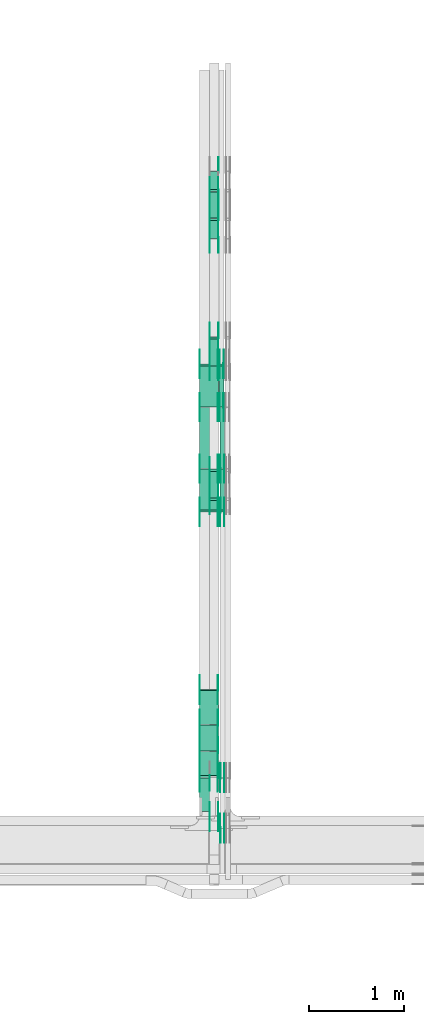
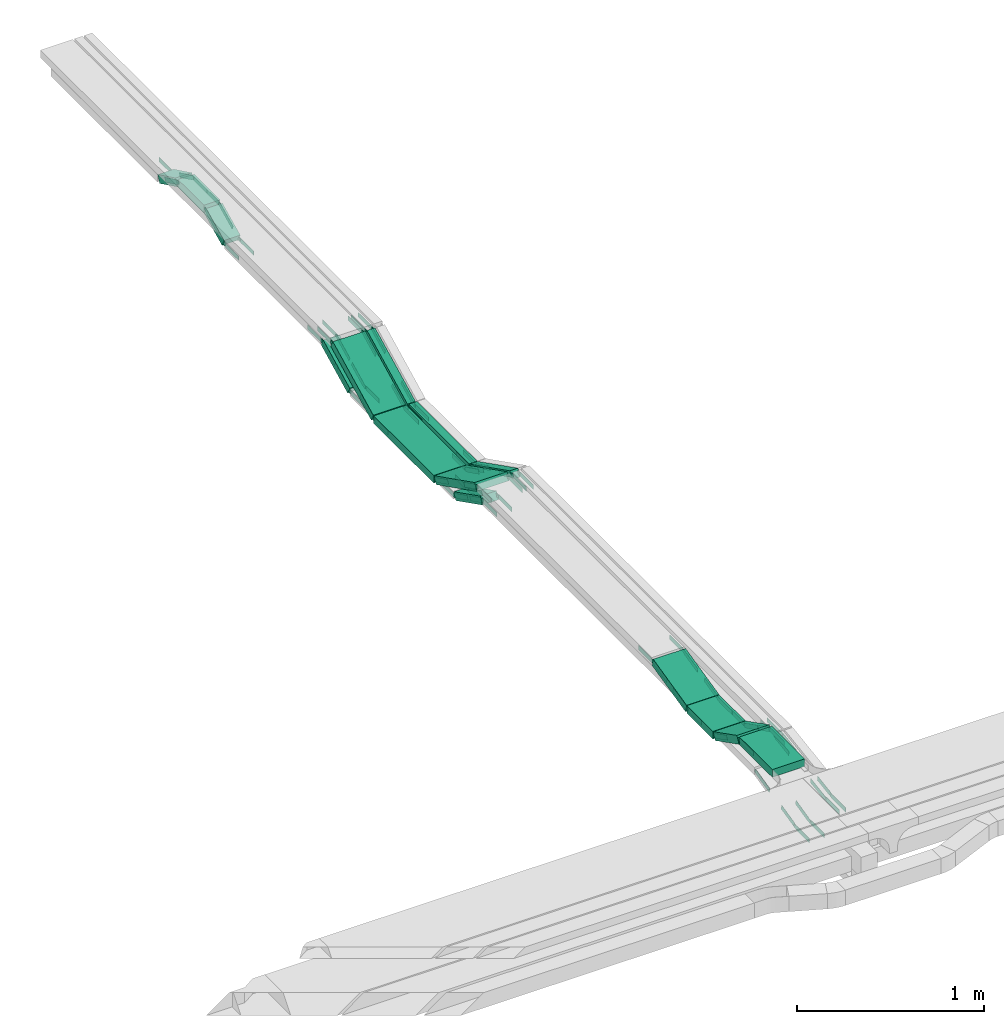
# One storey, part 18 of 28: 90 flow fittings, 15 flow segments.
"""IFC2X3 building model written with IfcOpenShell, lengths in millimetres."""

from ifc_helpers import new_model, entity, si_unit, converted_unit, derived_unit, direction, frame, frame_2d, origin, origin_2d_with_axis, place, context, subcontext, project, spatial, polyline, circle_curve, parameter, trimmed, segment, composite_curve, rectangle, outline, extrude, source, transform, mapped, material, type_object, type_shapes, element, save


model = new_model("IFC2X3")

# Units and contexts
model_context = context("Model", 3, precision=0.01, world=origin(), true_north=direction((6.12303176911189e-17, 1.0)))
body_context = subcontext(model_context, "Body", "Model", "MODEL_VIEW")
ifc_project = project(units=[si_unit("LENGTHUNIT", "METRE", prefix="MILLI"), si_unit("AREAUNIT", "SQUARE_METRE"), si_unit("VOLUMEUNIT", "CUBIC_METRE"), converted_unit("PLANEANGLEUNIT", "DEGREE", entity("IfcRatioMeasure", 0.0174532925199433), si_unit("PLANEANGLEUNIT", "RADIAN"), dimensions=[0, 0, 0, 0, 0, 0, 0]), si_unit("MASSUNIT", "GRAM", prefix="KILO"), derived_unit("MASSDENSITYUNIT", [(si_unit("MASSUNIT", "GRAM", prefix="KILO"), 1), (si_unit("LENGTHUNIT", "METRE"), -3)]), derived_unit("MOMENTOFINERTIAUNIT", [(si_unit("LENGTHUNIT", "METRE"), 4)]), si_unit("TIMEUNIT", "SECOND"), si_unit("FREQUENCYUNIT", "HERTZ"), si_unit("THERMODYNAMICTEMPERATUREUNIT", "DEGREE_CELSIUS"), derived_unit("THERMALTRANSMITTANCEUNIT", [(si_unit("MASSUNIT", "GRAM", prefix="KILO"), 1), (si_unit("THERMODYNAMICTEMPERATUREUNIT", "KELVIN"), -1), (si_unit("TIMEUNIT", "SECOND"), -3)]), derived_unit("VOLUMETRICFLOWRATEUNIT", [(si_unit("LENGTHUNIT", "METRE"), 3), (si_unit("TIMEUNIT", "SECOND"), -1)]), derived_unit("MASSFLOWRATEUNIT", [(si_unit("MASSUNIT", "GRAM", prefix="KILO"), 1), (si_unit("TIMEUNIT", "SECOND"), -1)]), derived_unit("ROTATIONALFREQUENCYUNIT", [(si_unit("TIMEUNIT", "SECOND"), -1)]), si_unit("ELECTRICCURRENTUNIT", "AMPERE"), si_unit("ELECTRICVOLTAGEUNIT", "VOLT"), si_unit("POWERUNIT", "WATT"), si_unit("FORCEUNIT", "NEWTON", prefix="KILO"), si_unit("ILLUMINANCEUNIT", "LUX"), si_unit("LUMINOUSFLUXUNIT", "LUMEN"), si_unit("LUMINOUSINTENSITYUNIT", "CANDELA"), derived_unit("USERDEFINED", [(si_unit("MASSUNIT", "GRAM", prefix="KILO"), -1), (si_unit("LENGTHUNIT", "METRE"), -2), (si_unit("TIMEUNIT", "SECOND"), 3), (si_unit("LUMINOUSFLUXUNIT", "LUMEN"), 1)]), derived_unit("LINEARVELOCITYUNIT", [(si_unit("LENGTHUNIT", "METRE"), 1), (si_unit("TIMEUNIT", "SECOND"), -1)]), si_unit("PRESSUREUNIT", "PASCAL"), derived_unit("USERDEFINED", [(si_unit("LENGTHUNIT", "METRE"), -2), (si_unit("MASSUNIT", "GRAM", prefix="KILO"), 1), (si_unit("TIMEUNIT", "SECOND"), -2)]), derived_unit("LINEARFORCEUNIT", [(si_unit("MASSUNIT", "GRAM", prefix="KILO"), 1), (si_unit("LENGTHUNIT", "METRE"), 1), (si_unit("TIMEUNIT", "SECOND"), -2), (si_unit("LENGTHUNIT", "METRE"), -1)]), derived_unit("PLANARFORCEUNIT", [(si_unit("MASSUNIT", "GRAM", prefix="KILO"), 1), (si_unit("LENGTHUNIT", "METRE"), 1), (si_unit("TIMEUNIT", "SECOND"), -2), (si_unit("LENGTHUNIT", "METRE"), -2)])], contexts=[model_context])

# Site, building, storey
site_placement = place(None, frame((0.0, -0.00077364408347762, 0.0)))
site = spatial("IfcSite", under=ifc_project, at=site_placement, CompositionType="ELEMENT")
building_placement = place(site_placement, origin())
building = spatial("IfcBuilding", under=site, at=building_placement, CompositionType="ELEMENT")
storey_placement = place(building_placement, origin())
storey = spatial("IfcBuildingStorey", under=building, at=storey_placement, CompositionType="ELEMENT", Elevation=0.0)

# Flow segments
cable_carrier_segment_type = type_object("IfcCableCarrierSegmentType", PredefinedType="CABLETRAYSEGMENT")
flow_segment_1_placement = place(storey_placement, frame((46847.7697248975, 13767.2948967149, 2456.22912852287)))
element("IfcFlowSegment", 1, at=flow_segment_1_placement, inside=storey, type_object=cable_carrier_segment_type, context=body_context, shape_type="SweptSolid", body=[
    extrude(rectangle(XDim=50.0000000000002, YDim=317.472558766538, at=frame_2d((0.0, 0.0), x_axis=(0.0, 1.0))), frame((0.0, 153.000824609062, 93.7708714771263), z_axis=(1.0, 0.0, 0.0), x_axis=(0.0, -0.892980854207483, -0.450094650066931)), (0.0, 0.0, 1.0), 99.9999999999946),
])
flow_segment_2_placement = place(storey_placement, frame((46847.7697248975, 12350.3050523624, 2456.22912852286)))
element("IfcFlowSegment", 2, at=flow_segment_2_placement, inside=storey, type_object=cable_carrier_segment_type, context=body_context, shape_type="SweptSolid", body=[
    extrude(rectangle(XDim=50.0000000000016, YDim=317.472558766714, at=frame_2d((2.41584530158434e-13, -4.81392703477468e-13), x_axis=(0.0, 1.0))), frame((0.0, 153.000824609155, 93.7708714771301), z_axis=(1.0, 0.0, 0.0), x_axis=(0.0, 0.89298085420761, -0.45009465006668)), (0.0, 0.0, 1.0), 99.9999999999946),
])
flow_segment_3_placement = place(storey_placement, frame((46959.820904201, 12227.7977453007, 2581.18180349081)))
element("IfcFlowSegment", 3, at=flow_segment_3_placement, inside=storey, type_object=cable_carrier_segment_type, context=body_context, shape_type="SweptSolid", body=[
    extrude(rectangle(XDim=49.9999999999997, YDim=484.209321850172, at=frame_2d((0.0, 0.0), x_axis=(0.0, 1.0))), frame((0.0, 227.447193172448, 131.294533993179), z_axis=(1.0, 0.0, 0.0), x_axis=(0.0, 0.892980854208928, -0.450094650064066)), (0.0, 0.0, 1.0), 50.000000000006),
])
flow_segment_4_placement = place(storey_placement, frame((46959.820904201, 12686.3854911002, 2574.95267496797)))
element("IfcFlowSegment", 4, at=flow_segment_4_placement, inside=storey, type_object=cable_carrier_segment_type, context=body_context, shape_type="SweptSolid", body=[
    extrude(rectangle(XDim=642.104660924055, YDim=50.000000000006, at=origin_2d_with_axis()), frame((25.0, 321.052330462028, 0.0), z_axis=(0.0, 0.0, 1.0), x_axis=(0.0, 1.0, 0.0)), (0.0, 0.0, 1.0), 49.9999999999995),
])
flow_segment_5_placement = place(storey_placement, frame((46952.1849606245, 13332.1835114787, 2581.18180348874)))
element("IfcFlowSegment", 5, at=flow_segment_5_placement, inside=storey, type_object=cable_carrier_segment_type, context=body_context, shape_type="SweptSolid", body=[
    extrude(rectangle(XDim=50.000000000001, YDim=484.209321850269, at=frame_2d((1.20792265079217e-12, 0.0), x_axis=(0.0, 1.0))), frame((0.0, 227.44719317206, 131.29453399422), z_axis=(1.0, 0.0, 0.0), x_axis=(0.0, -0.892980854206691, -0.450094650068503)), (0.0, 0.0, 1.0), 50.000000000006),
])
flow_segment_6_placement = place(storey_placement, frame((46742.1849606245, 12227.7977453008, 2581.18180349039)))
element("IfcFlowSegment", 6, at=flow_segment_6_placement, inside=storey, type_object=cable_carrier_segment_type, context=body_context, shape_type="SweptSolid", body=[
    extrude(rectangle(XDim=50.0000000000007, YDim=484.209321849835, at=frame_2d((1.27897692436818e-13, -2.36255459640233e-13), x_axis=(0.0, 1.0))), frame((0.0, 227.447193172292, 131.294533993118), z_axis=(1.0, 0.0, 0.0), x_axis=(0.0, 0.892980854208896, -0.450094650064129)), (0.0, 0.0, 1.0), 200.000000000007),
])
flow_segment_7_placement = place(storey_placement, frame((46742.1849606245, 12686.3854911, 2574.95267496752)))
element("IfcFlowSegment", 7, at=flow_segment_7_placement, inside=storey, type_object=cable_carrier_segment_type, context=body_context, shape_type="SweptSolid", body=[
    extrude(rectangle(XDim=642.104660927451, YDim=200.000000000007, at=frame_2d((-2.1600499167107e-12, 0.0), x_axis=(1.0, 0.0))), frame((100.0, 321.052330463728, 0.0), z_axis=(0.0, 0.0, 1.0), x_axis=(0.0, 1.0, 0.0)), (0.0, 0.0, 1.0), 50.0000000000005),
])
flow_segment_8_placement = place(storey_placement, frame((46742.1849606245, 13332.183511482, 2581.18180349044)))
element("IfcFlowSegment", 8, at=flow_segment_8_placement, inside=storey, type_object=cable_carrier_segment_type, context=body_context, shape_type="SweptSolid", body=[
    extrude(rectangle(XDim=50.0000000000005, YDim=484.209321846522, at=frame_2d((0.0, 0.0), x_axis=(0.0, 1.0))), frame((0.0, 227.447193170405, 131.294533993333), z_axis=(1.0, 0.0, 0.0), x_axis=(0.0, -0.892980854206786, -0.450094650068315)), (0.0, 0.0, 1.0), 200.000000000007),
])
flow_segment_9_placement = place(storey_placement, frame((46742.1849606245, 9070.00006103515, 2850.0)))
element("IfcFlowSegment", 9, at=flow_segment_9_placement, inside=storey, type_object=cable_carrier_segment_type, context=body_context, shape_type="SweptSolid", body=[
    extrude(rectangle(XDim=352.037715986697, YDim=200.000000000007, at=origin_2d_with_axis()), frame((100.0, 176.018857993349, 0.0), z_axis=(0.0, 0.0, 1.0), x_axis=(0.0, 1.0, 0.0)), (0.0, 0.0, 1.0), 49.9999999999995),
])
flow_segment_10_placement = place(storey_placement, frame((46742.1849606245, 9425.74474554499, 2720.14248827121)))
element("IfcFlowSegment", 10, at=flow_segment_10_placement, inside=storey, type_object=cable_carrier_segment_type, context=body_context, shape_type="SweptSolid", body=[
    extrude(rectangle(XDim=49.9999999999994, YDim=284.075431974124, at=frame_2d((3.5527136788005e-13, 4.86721773995669e-13), x_axis=(0.0, 1.0))), frame((0.0, 137.906294118772, 86.7589367675452), z_axis=(1.0, 0.0, 0.0), x_axis=(0.0, 0.891006524188341, -0.453990499739599)), (0.0, 0.0, 1.0), 200.000000000007),
])
flow_segment_11_placement = place(storey_placement, frame((46742.1849606245, 9705.26430230569, 2713.80285007765)))
element("IfcFlowSegment", 11, at=flow_segment_11_placement, inside=storey, type_object=cable_carrier_segment_type, context=body_context, shape_type="SweptSolid", body=[
    extrude(rectangle(XDim=277.662391313806, YDim=200.000000000007, at=frame_2d((5.54223333892878e-13, 0.0), x_axis=(1.0, 0.0))), frame((100.0, 138.831195656904, 0.0), z_axis=(0.0, 0.0, 1.0), x_axis=(0.0, 1.0, 0.0)), (0.0, 0.0, 1.0), 49.9999999999995),
])
flow_segment_12_placement = place(storey_placement, frame((46742.1849606245, 9985.81864117691, 2715.4760141411)))
element("IfcFlowSegment", 12, at=flow_segment_12_placement, inside=storey, type_object=cable_carrier_segment_type, context=body_context, shape_type="SweptSolid", body=[
    extrude(rectangle(XDim=49.9999999999991, YDim=366.558489644676, at=frame_2d((-1.06581410364015e-12, 2.45137243837235e-13), x_axis=(0.0, 1.0))), frame((0.0, 184.121681664649, 66.4254108974635), z_axis=(1.0, 0.0, 0.0), x_axis=(0.0, 0.973268623518919, 0.229669733473065)), (0.0, 0.0, 1.0), 200.000000000007),
])
flow_segment_13_placement = place(storey_placement, frame((46847.7697248975, 15325.7073557057, 2700.0)))
element("IfcFlowSegment", 13, at=flow_segment_13_placement, inside=storey, type_object=cable_carrier_segment_type, context=body_context, shape_type="SweptSolid", body=[
    extrude(rectangle(XDim=276.67146144988, YDim=99.9999999999946, at=origin_2d_with_axis()), frame((50.0, 138.33573072494, 0.0), z_axis=(0.0, 0.0, 1.0), x_axis=(0.0, 1.0, 0.0)), (0.0, 0.0, 1.0), 49.9999999999995),
])
flow_segment_14_placement = place(storey_placement, frame((46847.7697248975, 15108.938895096, 2605.90349264662)))
element("IfcFlowSegment", 14, at=flow_segment_14_placement, inside=storey, type_object=cable_carrier_segment_type, context=body_context, shape_type="SweptSolid", body=[
    extrude(rectangle(XDim=50.0000000000002, YDim=212.726848185128, at=frame_2d((1.13686837721616e-13, 2.45137243837235e-13), x_axis=(0.0, 1.0))), frame((0.0, 106.558090988111, 69.0965073533718), z_axis=(1.0, 0.0, 0.0), x_axis=(0.0, -0.89879404629905, -0.438371146789316)), (0.0, 0.0, 1.0), 99.9999999999946),
])
flow_segment_15_placement = place(storey_placement, frame((46847.7697248975, 15606.031095789, 2605.90349264662)))
element("IfcFlowSegment", 15, at=flow_segment_15_placement, inside=storey, type_object=cable_carrier_segment_type, context=body_context, shape_type="SweptSolid", body=[
    extrude(rectangle(XDim=50.0000000000002, YDim=212.726848185074, at=frame_2d((1.08713038571295e-12, 2.34479102800833e-13), x_axis=(0.0, 1.0))), frame((0.0, 106.558090988081, 69.0965073533702), z_axis=(1.0, 0.0, 0.0), x_axis=(0.0, 0.898794046298997, -0.438371146789427)), (0.0, 0.0, 1.0), 99.9999999999945),
])

# Flow fittings
ifc_material = material(Name="G")
cable_carrier_fitting_type_1 = type_object("IfcCableCarrierFittingType", PredefinedType="NOTDEFINED", material=ifc_material)
shared_shape_1 = source(origin(), body_context, "Body", "SweptSolid", [
    extrude(outline(composite_curve([segment(trimmed(circle_curve(frame_2d((-44.5901162790698, 0.0), x_axis=(1.0, 0.0)), 12.5), [parameter(90.0000000000007)], [parameter(270.0)], True, "PARAMETER"), True, "CONTINUOUS"), segment(polyline([(-44.5901162790697, -12.5), (-33.0901162790698, -12.5)]), True, "CONTINUOUS"), segment(polyline([(-33.0901162790698, -12.5), (-31.2296511627907, -14.5)]), True, "CONTINUOUS"), segment(polyline([(-31.2296511627907, -14.5), (108.90988372093, -14.5)]), True, "CONTINUOUS"), segment(polyline([(108.90988372093, -14.5), (108.90988372093, 14.5)]), True, "CONTINUOUS"), segment(polyline([(108.90988372093, 14.5), (-31.2296511627907, 14.5)]), True, "CONTINUOUS"), segment(polyline([(-31.2296511627907, 14.5), (-33.0901162790698, 12.5)]), True, "CONTINUOUS"), segment(polyline([(-33.0901162790698, 12.5), (-44.5901162790699, 12.5)]), True, "CONTINUOUS")], self_intersect=False)), frame((44.5901162790698, 0.0, 0.0), z_axis=(0.0, 0.0, -1.0), x_axis=(1.0, 0.0, 0.0)), (0.0, 0.0, -1.0), 2.0),
])
type_shapes(cable_carrier_fitting_type_1, [shared_shape_1])
for number, where, z_axis, x_axis in (
    (16, (46852.3097248873, 13771.4968763353, 2475.0), (-1.0, 0.0, 0.0), (0.0, -1.0, 0.0)),
    (17, (46943.2297249076, 12652.1047219603, 2475.0), (1.0, 0.0, 0.0), (0.0, 1.0, 0.0)),
    (18, (46943.2297249076, 12354.5070319827, 2625.0), (1.0, 0.0, 0.0), (0.0, -1.0, 0.0)),
    (19, (47005.2809042112, 12678.4901520253, 2599.95267496795), (1.0, 0.0, 0.0), (0.0, 1.0, 0.0)),
    (20, (46956.7249606144, 13782.8759182024, 2825.0), (-1.0, 0.0, 0.0), (0.0, 1.0, 0.0)),
    (21, (47005.2809042112, 12231.999724921, 2825.0), (1.0, 0.0, 0.0), (0.0, -1.0, 0.0)),
    (22, (46852.3097248873, 9016.12655809133, 2525.0), (-1.0, 0.0, 0.0), (0.0, -1.0, 0.0)),
    (23, (47005.2809042112, 8892.27683044921, 2745.0), (1.0, 0.0, 0.0), (0.0, 0.988943608506527, 0.148292073942234)),
    (24, (47005.2809042112, 9425.78807334492, 2825.0), (1.0, 0.0, 0.0), (0.0, -0.988943608506527, -0.148292073942234)),
    (25, (46746.7249606143, 9430.00006103517, 2875.0), (-1.0, 0.0, 0.0), (0.0, 0.891006524188341, -0.4539904997396)),
    (26, (46937.6449606347, 9697.30201829235, 2738.80285007763), (1.0, 0.0, 0.0), (0.0, 1.0, 0.0)),
    (27, (46937.6449606347, 9987.30201829213, 2738.80285007763), (1.0, 0.0, 0.0), (0.0, 0.97326862351892, 0.229669733473063)),
    (28, (46937.6449606347, 12231.9997249211, 2825.0), (1.0, 0.0, 0.0), (0.0, -1.0, 0.0)),
    (29, (46746.7249606143, 10352.578627391, 2825.0), (-1.0, 0.0, 0.0), (0.0, 1.0, 0.0)),
    (30, (46852.3097248873, 15318.012178163, 2725.0), (-1.0, 0.0, 0.0), (0.0, 1.0, 0.0)),
    (31, (46943.2297249076, 15610.0739946982, 2725.0), (1.0, 0.0, 0.0), (0.0, -1.0, 0.0)),
    (32, (46943.2297249076, 15815.1043788559, 2625.0), (1.0, 0.0, 0.0), (0.0, 1.0, 0.0)),
    (33, (46852.3097248873, 14069.0945663126, 2625.0), (-1.0, 0.0, 0.0), (0.0, 1.0, 0.0)),
    (34, (46852.3097248873, 15112.9817940052, 2625.0), (-1.0, 0.0, 0.0), (0.0, -1.0, 0.0)),
    (35, (46937.6449606347, 12678.4901520252, 2599.95267496753), (1.0, 0.0, 0.0), (0.0, 1.0, 0.0)),
    (36, (46937.6449606347, 13782.8759182024, 2825.0), (1.0, 0.0, 0.0), (0.0, -0.892980854206745, -0.450094650068397)),
    (37, (46937.6449606347, 13336.3854911024, 2599.95267496751), (1.0, 0.0, 0.0), (0.0, 0.892980854206745, 0.450094650068397)),
):
    element("IfcFlowFitting", number, at=place(storey_placement, frame(where, z_axis=z_axis, x_axis=x_axis)), inside=storey, type_object=cable_carrier_fitting_type_1, material=ifc_material, context=body_context, shape_type="MappedRepresentation", body=[
        mapped(shared_shape_1, transform((0.0, 0.0, 0.0), scale=1.0)),
    ])
cable_carrier_fitting_type_2 = type_object("IfcCableCarrierFittingType", PredefinedType="NOTDEFINED", material=ifc_material)
shared_shape_2 = source(origin(), body_context, "Body", "SweptSolid", [
    extrude(outline(composite_curve([segment(trimmed(circle_curve(frame_2d((-44.5901162790697, 0.0), x_axis=(1.0, 0.0)), 12.5), [parameter(90.0000000000007)], [parameter(270.0)], True, "PARAMETER"), True, "CONTINUOUS"), segment(polyline([(-44.5901162790697, -12.5), (-33.0901162790697, -12.5)]), True, "CONTINUOUS"), segment(polyline([(-33.0901162790697, -12.5), (-31.2296511627907, -14.5)]), True, "CONTINUOUS"), segment(polyline([(-31.2296511627907, -14.5), (108.90988372093, -14.5)]), True, "CONTINUOUS"), segment(polyline([(108.90988372093, -14.5), (108.90988372093, 14.5)]), True, "CONTINUOUS"), segment(polyline([(108.90988372093, 14.5), (-31.2296511627907, 14.5)]), True, "CONTINUOUS"), segment(polyline([(-31.2296511627907, 14.5), (-33.0901162790698, 12.5)]), True, "CONTINUOUS"), segment(polyline([(-33.0901162790698, 12.5), (-44.5901162790699, 12.5)]), True, "CONTINUOUS")], self_intersect=False)), frame((44.5901162790697, 0.0, 0.0)), (0.0, 0.0, 1.0), 2.0),
])
type_shapes(cable_carrier_fitting_type_2, [shared_shape_2])
for number, where, z_axis, x_axis in (
    (38, (46943.2297249076, 13771.4968763353, 2475.0), (1.0, 0.0, 0.0), (0.0, -1.0, 0.0)),
    (39, (46852.3097248873, 12652.1047219603, 2475.0), (-1.0, 0.0, 0.0), (0.0, 1.0, 0.0)),
    (40, (46852.3097248873, 12354.5070319827, 2625.0), (-1.0, 0.0, 0.0), (0.0, -1.0, 0.0)),
    (41, (46964.3609041909, 12678.4901520253, 2599.95267496795), (-1.0, 0.0, 0.0), (0.0, 1.0, 0.0)),
    (42, (46997.6449606347, 13782.8759182024, 2825.0), (1.0, 0.0, 0.0), (0.0, 1.0, 0.0)),
    (43, (46964.3609041909, 12231.999724921, 2825.0), (-1.0, 0.0, 0.0), (0.0, -1.0, 0.0)),
    (44, (46943.2297249076, 9016.12655809133, 2525.0), (1.0, 0.0, 0.0), (0.0, -1.0, 0.0)),
    (45, (46964.3609041909, 8892.27683044921, 2745.0), (-1.0, 0.0, 0.0), (0.0, 0.988943608506527, 0.148292073942234)),
    (46, (46964.3609041909, 9425.78807334492, 2825.0), (-1.0, 0.0, 0.0), (0.0, -0.988943608506527, -0.148292073942234)),
    (47, (46937.6449606347, 9430.00006103517, 2875.0), (1.0, 0.0, 0.0), (0.0, 0.891006524188341, -0.4539904997396)),
    (48, (46746.7249606143, 9697.30201829235, 2738.80285007763), (-1.0, 0.0, 0.0), (0.0, 1.0, 0.0)),
    (49, (46746.7249606143, 9987.30201829213, 2738.80285007763), (-1.0, 0.0, 0.0), (0.0, 0.97326862351892, 0.229669733473063)),
    (50, (46746.7249606143, 12231.9997249211, 2825.0), (-1.0, 0.0, 0.0), (0.0, -1.0, 0.0)),
    (51, (46937.6449606347, 10352.578627391, 2825.0), (1.0, 0.0, 0.0), (0.0, 1.0, 0.0)),
    (52, (46943.2297249076, 15318.012178163, 2725.0), (1.0, 0.0, 0.0), (0.0, 1.0, 0.0)),
    (53, (46852.3097248873, 15610.0739946982, 2725.0), (-1.0, 0.0, 0.0), (0.0, -1.0, 0.0)),
    (54, (46943.2297249076, 14069.0945663126, 2625.0), (1.0, 0.0, 0.0), (0.0, 1.0, 0.0)),
    (55, (46943.2297249076, 15112.9817940052, 2625.0), (1.0, 0.0, 0.0), (0.0, -1.0, 0.0)),
    (56, (46746.7249606143, 12678.4901520252, 2599.95267496752), (-1.0, 0.0, 0.0), (0.0, 1.0, 0.0)),
    (57, (46746.7249606143, 13782.8759182024, 2825.0), (-1.0, 0.0, 0.0), (0.0, -0.892980854206745, -0.450094650068397)),
    (58, (46746.7249606143, 13336.3854911023, 2599.95267496751), (-1.0, 0.0, 0.0), (0.0, 0.892980854206745, 0.450094650068397)),
):
    element("IfcFlowFitting", number, at=place(storey_placement, frame(where, z_axis=z_axis, x_axis=x_axis)), inside=storey, type_object=cable_carrier_fitting_type_2, material=ifc_material, context=body_context, shape_type="MappedRepresentation", body=[
        mapped(shared_shape_2, transform((0.0, 0.0, 0.0), scale=1.0)),
    ])
cable_carrier_fitting_type_3 = type_object("IfcCableCarrierFittingType", PredefinedType="NOTDEFINED", material=ifc_material)
shared_shape_3 = source(origin(), body_context, "Body", "SweptSolid", [
    extrude(outline(composite_curve([segment(trimmed(circle_curve(frame_2d((-44.5901162790698, 0.0), x_axis=(1.0, 0.0)), 12.5), [parameter(90.0000000000007)], [parameter(270.0)], True, "PARAMETER"), True, "CONTINUOUS"), segment(polyline([(-44.5901162790697, -12.5), (-33.0901162790698, -12.5)]), True, "CONTINUOUS"), segment(polyline([(-33.0901162790698, -12.5), (-31.2296511627907, -14.5)]), True, "CONTINUOUS"), segment(polyline([(-31.2296511627907, -14.5), (108.90988372093, -14.5)]), True, "CONTINUOUS"), segment(polyline([(108.90988372093, -14.5), (108.90988372093, 14.5)]), True, "CONTINUOUS"), segment(polyline([(108.90988372093, 14.5), (-31.2296511627907, 14.5)]), True, "CONTINUOUS"), segment(polyline([(-31.2296511627907, 14.5), (-33.0901162790698, 12.5)]), True, "CONTINUOUS"), segment(polyline([(-33.0901162790698, 12.5), (-44.5901162790699, 12.5)]), True, "CONTINUOUS")], self_intersect=False)), frame((44.5901162790698, 0.0, 0.0), z_axis=(0.0, 0.0, -1.0), x_axis=(1.0, 0.0, 0.0)), (0.0, 0.0, -1.0), 2.0),
])
type_shapes(cable_carrier_fitting_type_3, [shared_shape_3])
for number, where, z_axis, x_axis in (
    (59, (46941.2297249076, 13771.4968763353, 2475.0), (1.0, 0.0, 0.0), (0.0, 0.892980854206722, 0.450094650068442)),
    (60, (46854.3097248873, 12652.1047219603, 2475.0), (-1.0, 0.0, 0.0), (0.0, -0.892980854206722, 0.450094650068442)),
    (61, (46854.3097248873, 12354.5070319827, 2625.0), (-1.0, 0.0, 0.0), (0.0, 0.892980854206848, -0.450094650068192)),
    (62, (46966.3609041909, 12678.4901520253, 2599.95267496795), (-1.0, 0.0, 0.0), (0.0, -0.892980854206714, 0.450094650068457)),
    (63, (46995.6449606347, 13336.3854910991, 2599.95267496582), (1.0, 0.0, 0.0), (0.0, 0.892980854206714, 0.450094650068457)),
    (64, (46995.6449606347, 13782.8759182024, 2825.0), (1.0, 0.0, 0.0), (0.0, -0.892980854206701, -0.450094650068483)),
    (65, (46966.3609041909, 12231.999724921, 2825.0), (-1.0, 0.0, 0.0), (0.0, 0.892980854206734, -0.450094650068419)),
    (66, (46941.2297249076, 9016.12655809131, 2525.0), (1.0, 0.0, 0.0), (0.0, 0.973268623517807, 0.229669733477778)),
    (67, (46966.3609041909, 8892.27683044923, 2745.0), (-1.0, 0.0, 0.0), (0.0, -1.0, 0.0)),
    (68, (46966.3609041909, 9425.7880733449, 2825.0), (-1.0, 0.0, 0.0), (0.0, 1.0, 0.0)),
    (69, (46935.6449606347, 9430.00006103518, 2875.0), (1.0, 0.0, 0.0), (0.0, -1.0, 0.0)),
    (70, (46748.7249606143, 9697.30201829236, 2738.80285007763), (-1.0, 0.0, 0.0), (0.0, -0.891006524188359, 0.453990499739564)),
    (71, (46748.7249606143, 9987.30201829214, 2738.80285007764), (-1.0, 0.0, 0.0), (0.0, -1.0, 0.0)),
    (72, (46748.7249606143, 12231.9997249211, 2825.0), (-1.0, 0.0, 0.0), (0.0, 0.892980854206683, -0.45009465006852)),
    (73, (46935.6449606347, 10352.578627391, 2825.0), (1.0, 0.0, 0.0), (0.0, -0.973268623518927, -0.229669733473034)),
    (74, (46941.2297249076, 15318.012178163, 2725.0), (1.0, 0.0, 0.0), (0.0, -0.898794046298952, -0.438371146789519)),
    (75, (46854.3097248873, 15610.0739946982, 2725.0), (-1.0, 0.0, 0.0), (0.0, 0.898794046298952, -0.438371146789519)),
    (76, (46941.2297249076, 14069.0945663127, 2625.0), (1.0, 0.0, 0.0), (0.0, -0.892980854207486, -0.450094650066926)),
    (77, (46941.2297249076, 15112.9817940051, 2625.0), (1.0, 0.0, 0.0), (0.0, 0.898794046299068, 0.43837114678928)),
    (78, (46748.7249606143, 12678.4901520252, 2599.95267496752), (-1.0, 0.0, 0.0), (0.0, -0.892980854208899, 0.450094650064124)),
    (79, (46748.7249606143, 13782.8759182024, 2825.0), (-1.0, 0.0, 0.0), (0.0, 1.0, 0.0)),
    (80, (46748.7249606143, 13336.3854911024, 2599.95267496751), (-1.0, 0.0, 0.0), (0.0, -1.0, 0.0)),
):
    element("IfcFlowFitting", number, at=place(storey_placement, frame(where, z_axis=z_axis, x_axis=x_axis)), inside=storey, type_object=cable_carrier_fitting_type_3, material=ifc_material, context=body_context, shape_type="MappedRepresentation", body=[
        mapped(shared_shape_3, transform((0.0, 0.0, 0.0), scale=1.0)),
    ])
cable_carrier_fitting_type_4 = type_object("IfcCableCarrierFittingType", PredefinedType="NOTDEFINED", material=ifc_material)
shared_shape_4 = source(origin(), body_context, "Body", "SweptSolid", [
    extrude(outline(composite_curve([segment(trimmed(circle_curve(frame_2d((-44.5901162790697, 0.0), x_axis=(1.0, 0.0)), 12.5), [parameter(90.0000000000007)], [parameter(270.0)], True, "PARAMETER"), True, "CONTINUOUS"), segment(polyline([(-44.5901162790697, -12.5), (-33.0901162790697, -12.5)]), True, "CONTINUOUS"), segment(polyline([(-33.0901162790697, -12.5), (-31.2296511627907, -14.5)]), True, "CONTINUOUS"), segment(polyline([(-31.2296511627907, -14.5), (108.90988372093, -14.5)]), True, "CONTINUOUS"), segment(polyline([(108.90988372093, -14.5), (108.90988372093, 14.5)]), True, "CONTINUOUS"), segment(polyline([(108.90988372093, 14.5), (-31.2296511627907, 14.5)]), True, "CONTINUOUS"), segment(polyline([(-31.2296511627907, 14.5), (-33.0901162790698, 12.5)]), True, "CONTINUOUS"), segment(polyline([(-33.0901162790698, 12.5), (-44.5901162790699, 12.5)]), True, "CONTINUOUS")], self_intersect=False)), frame((44.5901162790697, 0.0, 0.0)), (0.0, 0.0, 1.0), 2.0),
])
type_shapes(cable_carrier_fitting_type_4, [shared_shape_4])
for number, where, z_axis, x_axis in (
    (81, (46854.3097248873, 13771.4968763353, 2475.0), (-1.0, 0.0, 0.0), (0.0, 0.892980854206722, 0.450094650068442)),
    (82, (46941.2297249076, 12652.1047219603, 2475.0), (1.0, 0.0, 0.0), (0.0, -0.892980854206722, 0.450094650068442)),
    (83, (46854.3097248873, 9439.89533631955, 2625.0), (-1.0, 0.0, 0.0), (0.0, -0.973268623517807, -0.229669733477778)),
    (84, (46941.2297249076, 12354.5070319827, 2625.0), (1.0, 0.0, 0.0), (0.0, 0.892980854206848, -0.450094650068192)),
    (85, (47003.2809042112, 12678.4901520253, 2599.95267496795), (1.0, 0.0, 0.0), (0.0, -0.892980854206714, 0.450094650068457)),
    (86, (46958.7249606144, 13336.3854910991, 2599.95267496582), (-1.0, 0.0, 0.0), (0.0, 0.892980854206714, 0.450094650068457)),
    (87, (46958.7249606144, 13782.8759182024, 2825.0), (-1.0, 0.0, 0.0), (0.0, -0.892980854206701, -0.450094650068483)),
    (88, (47003.2809042112, 12231.999724921, 2825.0), (1.0, 0.0, 0.0), (0.0, 0.892980854206734, -0.450094650068419)),
    (89, (46854.3097248873, 9016.12655809131, 2525.0), (-1.0, 0.0, 0.0), (0.0, 0.973268623517807, 0.229669733477778)),
    (90, (47003.2809042112, 8892.27683044923, 2745.0), (1.0, 0.0, 0.0), (0.0, -1.0, 0.0)),
    (91, (47003.2809042112, 9425.7880733449, 2825.0), (1.0, 0.0, 0.0), (0.0, 1.0, 0.0)),
    (92, (46748.7249606143, 9430.00006103518, 2875.0), (-1.0, 0.0, 0.0), (0.0, -1.0, 0.0)),
    (93, (46935.6449606347, 9697.30201829236, 2738.80285007763), (1.0, 0.0, 0.0), (0.0, -0.891006524188359, 0.453990499739564)),
    (94, (46935.6449606347, 9987.30201829214, 2738.80285007764), (1.0, 0.0, 0.0), (0.0, -1.0, 0.0)),
    (95, (46935.6449606347, 12231.9997249211, 2825.0), (1.0, 0.0, 0.0), (0.0, 0.892980854206683, -0.45009465006852)),
    (96, (46748.7249606143, 10352.578627391, 2825.0), (-1.0, 0.0, 0.0), (0.0, -0.973268623518927, -0.229669733473034)),
    (97, (46854.3097248873, 15318.012178163, 2725.0), (-1.0, 0.0, 0.0), (0.0, -0.898794046298952, -0.438371146789519)),
    (98, (46941.2297249076, 15610.0739946982, 2725.0), (1.0, 0.0, 0.0), (0.0, 0.898794046298952, -0.438371146789519)),
    (99, (46854.3097248873, 14069.0945663127, 2625.0), (-1.0, 0.0, 0.0), (0.0, -0.892980854207486, -0.450094650066926)),
    (100, (46854.3097248873, 15112.9817940051, 2625.0), (-1.0, 0.0, 0.0), (0.0, 0.898794046299068, 0.43837114678928)),
    (101, (46935.6449606347, 12678.4901520252, 2599.95267496753), (1.0, 0.0, 0.0), (0.0, -0.892980854208899, 0.450094650064124)),
    (102, (46935.6449606347, 13782.8759182024, 2825.0), (1.0, 0.0, 0.0), (0.0, 1.0, 0.0)),
    (103, (46935.6449606347, 13336.3854911024, 2599.95267496752), (1.0, 0.0, 0.0), (0.0, -1.0, 0.0)),
):
    element("IfcFlowFitting", number, at=place(storey_placement, frame(where, z_axis=z_axis, x_axis=x_axis)), inside=storey, type_object=cable_carrier_fitting_type_4, material=ifc_material, context=body_context, shape_type="MappedRepresentation", body=[
        mapped(shared_shape_4, transform((0.0, 0.0, 0.0), scale=1.0)),
    ])
cable_carrier_fitting_type_5 = type_object("IfcCableCarrierFittingType", PredefinedType="NOTDEFINED", material=ifc_material)
shared_shape_5 = source(origin(), body_context, "Body", "SweptSolid", [
    extrude(outline(composite_curve([segment(trimmed(circle_curve(frame_2d((-44.5901162790697, 0.0), x_axis=(1.0, 0.0)), 12.5), [parameter(90.0000000000007)], [parameter(270.0)], True, "PARAMETER"), True, "CONTINUOUS"), segment(polyline([(-44.5901162790697, -12.5), (-33.0901162790697, -12.5)]), True, "CONTINUOUS"), segment(polyline([(-33.0901162790697, -12.5), (-31.2296511627907, -14.5)]), True, "CONTINUOUS"), segment(polyline([(-31.2296511627907, -14.5), (108.90988372093, -14.5)]), True, "CONTINUOUS"), segment(polyline([(108.90988372093, -14.5), (108.90988372093, 14.5)]), True, "CONTINUOUS"), segment(polyline([(108.90988372093, 14.5), (-31.2296511627907, 14.5)]), True, "CONTINUOUS"), segment(polyline([(-31.2296511627907, 14.5), (-33.0901162790698, 12.5)]), True, "CONTINUOUS"), segment(polyline([(-33.0901162790698, 12.5), (-44.5901162790699, 12.5)]), True, "CONTINUOUS")], self_intersect=False)), frame((44.5901162790697, 0.0, 0.0)), (0.0, 0.0, 1.0), 2.0),
])
type_shapes(cable_carrier_fitting_type_5, [shared_shape_5])
flow_fitting_1_placement = place(storey_placement, frame((46997.6449606347, 13336.3854910991, 2599.95267496582), z_axis=(1.0, 0.0, 0.0), x_axis=(0.0, -1.0, 0.0)))
element("IfcFlowFitting", 104, at=flow_fitting_1_placement, inside=storey, type_object=cable_carrier_fitting_type_5, material=ifc_material, context=body_context, shape_type="MappedRepresentation", body=[
    mapped(shared_shape_5, transform((0.0, 0.0, 0.0), scale=1.0)),
])
cable_carrier_fitting_type_6 = type_object("IfcCableCarrierFittingType", PredefinedType="NOTDEFINED", material=ifc_material)
shared_shape_6 = source(origin(), body_context, "Body", "SweptSolid", [
    extrude(outline(composite_curve([segment(trimmed(circle_curve(frame_2d((-44.5901162790698, 0.0), x_axis=(1.0, 0.0)), 12.5), [parameter(90.0000000000007)], [parameter(270.0)], True, "PARAMETER"), True, "CONTINUOUS"), segment(polyline([(-44.5901162790697, -12.5), (-33.0901162790698, -12.5)]), True, "CONTINUOUS"), segment(polyline([(-33.0901162790698, -12.5), (-31.2296511627907, -14.5)]), True, "CONTINUOUS"), segment(polyline([(-31.2296511627907, -14.5), (108.90988372093, -14.5)]), True, "CONTINUOUS"), segment(polyline([(108.90988372093, -14.5), (108.90988372093, 14.5)]), True, "CONTINUOUS"), segment(polyline([(108.90988372093, 14.5), (-31.2296511627907, 14.5)]), True, "CONTINUOUS"), segment(polyline([(-31.2296511627907, 14.5), (-33.0901162790698, 12.5)]), True, "CONTINUOUS"), segment(polyline([(-33.0901162790698, 12.5), (-44.5901162790699, 12.5)]), True, "CONTINUOUS")], self_intersect=False)), frame((44.5901162790698, 0.0, 0.0), z_axis=(0.0, 0.0, -1.0), x_axis=(1.0, 0.0, 0.0)), (0.0, 0.0, -1.0), 2.0),
])
type_shapes(cable_carrier_fitting_type_6, [shared_shape_6])
flow_fitting_2_placement = place(storey_placement, frame((46956.7249606144, 13336.3854910991, 2599.95267496582), z_axis=(-1.0, 0.0, 0.0), x_axis=(0.0, -1.0, 0.0)))
element("IfcFlowFitting", 105, at=flow_fitting_2_placement, inside=storey, type_object=cable_carrier_fitting_type_6, material=ifc_material, context=body_context, shape_type="MappedRepresentation", body=[
    mapped(shared_shape_6, transform((0.0, 0.0, 0.0), scale=1.0)),
])

save(model, "model.ifc")
